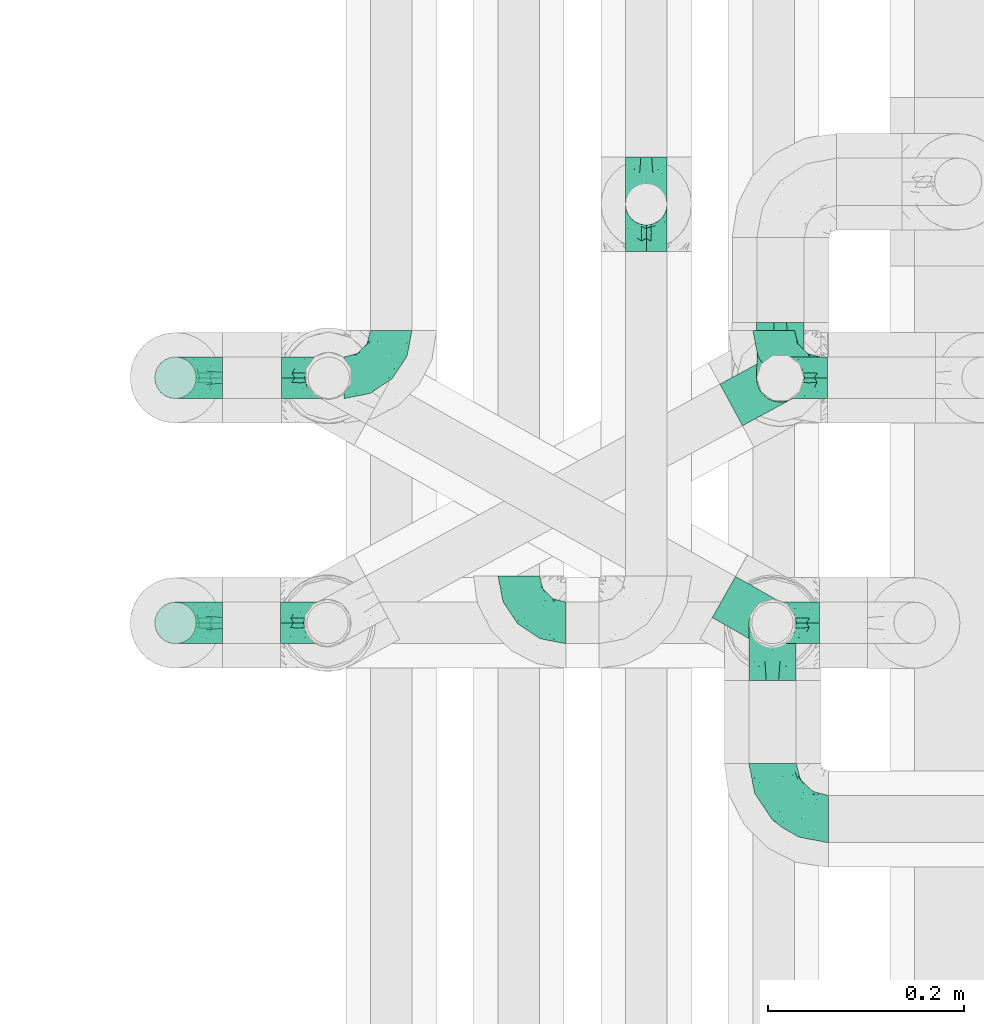
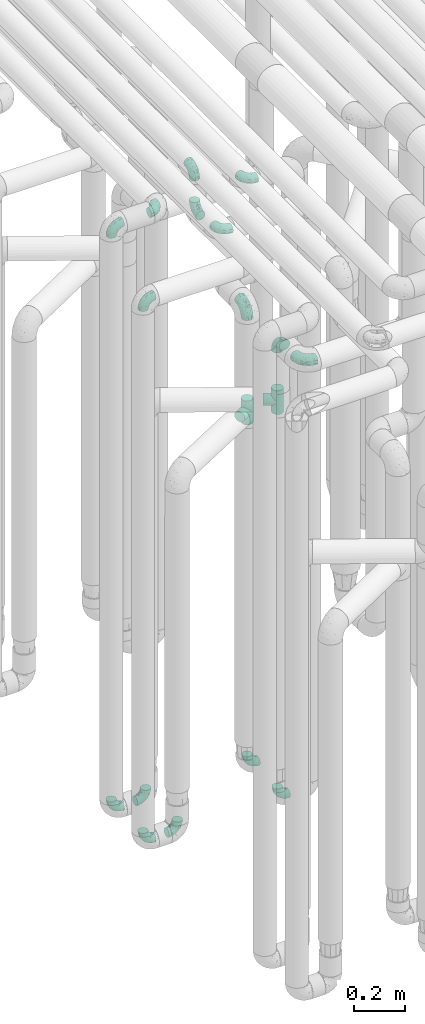
# One storey, part 600 of 827: 18 flow fittings.
"""IFC2X3 building model written with IfcOpenShell, lengths in millimetres."""

from ifc_helpers import new_model, entity, si_unit, converted_unit, derived_unit, direction, frame, origin, place, context, subcontext, project, spatial, faceted_brep, source, transform, mapped, material, type_object, type_shapes, element, save


model = new_model("IFC2X3")

# Units and contexts
model_context = context("Model", 3, precision=0.01, world=origin(), true_north=direction((6.12303176911189e-17, 1.0)))
body_context = subcontext(model_context, "Body", "Model", "MODEL_VIEW")
ifc_project = project(units=[si_unit("LENGTHUNIT", "METRE", prefix="MILLI"), si_unit("AREAUNIT", "SQUARE_METRE"), si_unit("VOLUMEUNIT", "CUBIC_METRE"), converted_unit("PLANEANGLEUNIT", "DEGREE", entity("IfcRatioMeasure", 0.0174532925199433), si_unit("PLANEANGLEUNIT", "RADIAN"), dimensions=[0, 0, 0, 0, 0, 0, 0]), si_unit("MASSUNIT", "GRAM", prefix="KILO"), derived_unit("MASSDENSITYUNIT", [(si_unit("MASSUNIT", "GRAM", prefix="KILO"), 1), (si_unit("LENGTHUNIT", "METRE"), -3)]), derived_unit("MOMENTOFINERTIAUNIT", [(si_unit("LENGTHUNIT", "METRE"), 4)]), si_unit("TIMEUNIT", "SECOND"), si_unit("FREQUENCYUNIT", "HERTZ"), si_unit("THERMODYNAMICTEMPERATUREUNIT", "DEGREE_CELSIUS"), derived_unit("THERMALTRANSMITTANCEUNIT", [(si_unit("MASSUNIT", "GRAM", prefix="KILO"), 1), (si_unit("THERMODYNAMICTEMPERATUREUNIT", "KELVIN"), -1), (si_unit("TIMEUNIT", "SECOND"), -3)]), derived_unit("VOLUMETRICFLOWRATEUNIT", [(si_unit("LENGTHUNIT", "METRE"), 3), (si_unit("TIMEUNIT", "SECOND"), -1)]), derived_unit("MASSFLOWRATEUNIT", [(si_unit("MASSUNIT", "GRAM", prefix="KILO"), 1), (si_unit("TIMEUNIT", "SECOND"), -1)]), derived_unit("ROTATIONALFREQUENCYUNIT", [(si_unit("TIMEUNIT", "SECOND"), -1)]), si_unit("ELECTRICCURRENTUNIT", "AMPERE"), si_unit("ELECTRICVOLTAGEUNIT", "VOLT"), si_unit("POWERUNIT", "WATT"), si_unit("FORCEUNIT", "NEWTON", prefix="KILO"), si_unit("ILLUMINANCEUNIT", "LUX"), si_unit("LUMINOUSFLUXUNIT", "LUMEN"), si_unit("LUMINOUSINTENSITYUNIT", "CANDELA"), derived_unit("USERDEFINED", [(si_unit("MASSUNIT", "GRAM", prefix="KILO"), -1), (si_unit("LENGTHUNIT", "METRE"), -2), (si_unit("TIMEUNIT", "SECOND"), 3), (si_unit("LUMINOUSFLUXUNIT", "LUMEN"), 1)]), derived_unit("LINEARVELOCITYUNIT", [(si_unit("LENGTHUNIT", "METRE"), 1), (si_unit("TIMEUNIT", "SECOND"), -1)]), si_unit("PRESSUREUNIT", "PASCAL"), derived_unit("USERDEFINED", [(si_unit("LENGTHUNIT", "METRE"), -2), (si_unit("MASSUNIT", "GRAM", prefix="KILO"), 1), (si_unit("TIMEUNIT", "SECOND"), -2)]), derived_unit("LINEARFORCEUNIT", [(si_unit("MASSUNIT", "GRAM", prefix="KILO"), 1), (si_unit("LENGTHUNIT", "METRE"), 1), (si_unit("TIMEUNIT", "SECOND"), -2), (si_unit("LENGTHUNIT", "METRE"), -1)]), derived_unit("PLANARFORCEUNIT", [(si_unit("MASSUNIT", "GRAM", prefix="KILO"), 1), (si_unit("LENGTHUNIT", "METRE"), 1), (si_unit("TIMEUNIT", "SECOND"), -2), (si_unit("LENGTHUNIT", "METRE"), -2)])], contexts=[model_context])

# Site, building, storey
site_placement = place(None, origin())
site = spatial("IfcSite", under=ifc_project, at=site_placement, CompositionType="ELEMENT")
building_placement = place(site_placement, origin())
building = spatial("IfcBuilding", under=site, at=building_placement, CompositionType="ELEMENT")
storey_placement = place(building_placement, frame((0.0, 0.0, 28200.0)))
storey = spatial("IfcBuildingStorey", under=building, at=storey_placement, Name="08", CompositionType="ELEMENT", Elevation=28200.0)

# Flow fittings
ifc_material = material()
pipe_fitting_type_1 = type_object("IfcPipeFittingType", Name="ADSK_1", PredefinedType="NOTDEFINED", material=ifc_material)
shared_shape_1 = source(origin(), body_context, "Body", "Brep", [
    faceted_brep([(-57.0, 12.07, -20.91), (-57.0, 6.25, -23.33), (-57.0, 0.0, -24.15), (-57.0, -6.25, -23.33), (-57.0, -12.08, -20.91), (-57.0, -17.08, -17.08), (-57.0, -20.91, -12.08), (-57.0, -23.33, -6.25), (-57.0, -24.15, 0.0), (-57.0, -23.33, 6.25), (-57.0, -20.91, 12.07), (-57.0, -17.08, 17.08), (-57.0, -12.08, 20.91), (-57.0, -6.25, 23.33), (-57.0, 0.0, 24.15), (-57.0, 6.25, 23.33), (-57.0, 12.07, 20.91), (-57.0, 17.08, 17.08), (-57.0, 20.91, 12.07), (-57.0, 23.33, 6.25), (-57.0, 24.15, 0.0), (-57.0, 23.33, -6.25), (-57.0, 20.91, -12.08), (-57.0, 17.08, -17.08), (0.0, 57.0, -24.15), (-6.25, 57.0, -23.33), (-12.07, 57.0, -20.91), (-17.08, 57.0, -17.08), (-20.91, 57.0, -12.08), (-23.33, 57.0, -6.25), (-24.15, 57.0, 0.0), (-23.33, 57.0, 6.25), (-20.91, 57.0, 12.07), (-17.08, 57.0, 17.08), (-12.07, 57.0, 20.91), (-6.25, 57.0, 23.33), (0.0, 57.0, 24.15), (6.25, 57.0, 23.33), (12.08, 57.0, 20.91), (17.08, 57.0, 17.08), (20.91, 57.0, 12.07), (23.33, 57.0, 6.25), (24.15, 57.0, 0.0), (23.33, 57.0, -6.25), (20.91, 57.0, -12.08), (17.08, 57.0, -17.08), (12.08, 57.0, -20.91), (6.25, 57.0, -23.33), (14.9, 21.14, 6.17), (13.61, 24.64, 12.48), (6.23, 8.95, 8.98), (-41.47, -21.06, 0.0), (-41.92, -18.38, 13.72), (-24.64, -13.61, 12.48), (-37.37, -13.24, 18.15), (-6.8, -4.93, 8.18), (-21.76, -15.19, 6.22), (-12.78, -9.18, 0.0), (-37.73, -20.51, 7.75), (-7.38, 7.38, 20.24), (-23.37, -4.26, 20.42), (-11.9, -3.19, 15.86), (-42.14, -8.7, 21.82), (13.24, 37.37, 18.15), (9.33, 23.53, 16.85), (4.26, 23.37, 20.42), (2.77, 10.92, 15.55), (-29.46, 0.91, 23.52), (-44.13, 20.56, 15.69), (-39.25, 26.33, 10.88), (-49.02, 22.92, 9.96), (-34.58, 23.87, 17.15), (-15.8, 6.8, 22.81), (-8.67, 20.47, 23.88), (-18.12, 12.9, 24.08), (-48.29, 14.92, 19.65), (-44.06, -2.85, 23.78), (-9.23, 48.95, 22.58), (-3.78, 42.74, 24.07), (-40.34, 4.26, 24.09), (-44.02, 26.14, 5.46), (-44.04, 9.88, 22.74), (-4.95, 16.87, 22.52), (-2.75, 1.43, 12.5), (-25.48, 40.98, 10.71), (20.51, 37.73, 7.75), (18.38, 41.92, 13.72), (8.7, 42.14, 21.82), (-25.95, -17.97, 0.0), (2.85, 44.06, 23.78), (21.06, 41.47, 0.0), (17.97, 25.95, 0.0), (-24.04, -9.27, 17.13), (-33.26, 33.26, 5.86), (-28.55, 40.57, 0.0), (-40.57, 28.55, 0.0), (-25.29, 47.19, 4.06), (-27.01, 31.1, 16.77), (-15.7, 43.95, 19.9), (-20.27, 45.22, 15.61), (-30.53, 31.98, 12.64), (-11.28, 38.33, 22.92), (-9.97, 27.88, 24.09), (-20.15, 30.26, 21.25), (-31.25, 11.75, 23.64), (-28.75, 7.23, 24.15), (-29.53, 18.06, 22.27), (-28.44, 24.21, 20.02), (-37.55, 17.7, 20.26), (-15.88, 29.25, 22.99), (-20.82, 20.82, 23.44), (-0.91, 29.46, 23.52), (-13.5, -7.67, 12.04), (1.49, 1.56, 5.16), (8.86, 10.35, 4.59), (0.38, -0.38, 0.0), (9.18, 12.78, 0.0), (-37.37, -13.24, -18.15), (8.86, 10.35, -4.59), (-45.22, 20.27, -15.61), (-43.95, 15.7, -19.9), (-38.33, 11.28, -22.92), (-48.95, 9.23, -22.58), (-47.19, 25.29, -4.06), (-33.26, 33.26, -5.86), (18.38, 41.92, -13.72), (-30.26, 20.15, -21.25), (2.85, 44.06, -23.78), (-4.26, 40.34, -24.09), (-40.98, 25.48, -10.71), (-41.92, -18.38, -13.72), (9.25, 23.5, -16.92), (4.26, 23.37, -20.42), (13.24, 37.37, -18.15), (-37.73, -20.51, -7.75), (-11.75, 31.25, -23.64), (-7.23, 28.75, -24.15), (-12.9, 18.12, -24.08), (8.7, 42.14, -21.82), (-44.06, -2.85, -23.78), (-6.8, 15.8, -22.81), (-20.47, 8.67, -23.88), (-24.64, -13.61, -12.48), (-42.74, 3.78, -24.07), (-18.06, 29.53, -22.27), (-24.21, 28.44, -20.02), (-27.88, 9.97, -24.09), (-31.1, 27.01, -16.77), (-26.14, 44.02, -5.46), (14.9, 21.14, -6.17), (20.51, 37.73, -7.75), (-9.88, 44.04, -22.74), (-20.56, 44.13, -15.69), (-21.76, -15.19, -6.22), (-13.5, -7.67, -12.04), (-24.14, -9.76, -16.74), (-11.9, -3.19, -15.86), (-14.92, 48.29, -19.65), (-23.37, -4.26, -20.42), (-0.91, 29.46, -23.52), (-26.33, 39.25, -10.88), (-23.87, 34.58, -17.15), (-42.14, -8.7, -21.82), (-22.92, 49.02, -9.96), (13.61, 24.64, -12.48), (-31.98, 30.53, -12.64), (-16.87, 4.95, -22.52), (-17.7, 37.55, -20.26), (-29.25, 15.88, -22.99), (-20.82, 20.82, -23.44), (-29.46, 0.91, -23.52), (-7.38, 7.38, -20.24), (2.77, 10.92, -15.55), (6.23, 8.95, -8.98), (-6.8, -4.93, -8.18), (-2.81, 1.41, -12.54), (1.49, 1.56, -5.16)], [[[0, 1, 2, 3, 4, 5, 6, 7, 8, 9, 10, 11, 12, 13, 14, 15, 16, 17, 18, 19, 20, 21, 22, 23]], [[24, 25, 26, 27, 28, 29, 30, 31, 32, 33, 34, 35, 36, 37, 38, 39, 40, 41, 42, 43, 44, 45, 46, 47]], [[48, 49, 50]], [[9, 8, 51]], [[52, 53, 54]], [[55, 56, 57]], [[10, 58, 52]], [[9, 58, 10]], [[59, 60, 61]], [[54, 12, 11]], [[54, 62, 12]], [[63, 39, 38]], [[64, 65, 66]], [[62, 60, 67]], [[68, 69, 70]], [[71, 69, 68]], [[72, 73, 74]], [[16, 75, 17]], [[13, 76, 14]], [[35, 77, 78]], [[14, 79, 15]], [[17, 68, 18]], [[14, 76, 79]], [[20, 19, 80]], [[70, 19, 18]], [[81, 15, 79]], [[15, 81, 16]], [[73, 72, 82]], [[66, 83, 50]], [[32, 31, 84]], [[85, 86, 49]], [[63, 87, 65]], [[56, 58, 88]], [[36, 89, 37]], [[85, 41, 40]], [[36, 35, 78]], [[90, 41, 85]], [[40, 39, 86]], [[12, 62, 13]], [[86, 85, 40]], [[48, 85, 49]], [[85, 91, 90]], [[87, 38, 37]], [[92, 60, 54]], [[80, 69, 93]], [[93, 94, 95]], [[10, 52, 11]], [[94, 96, 30]], [[97, 98, 99]], [[80, 93, 95]], [[100, 97, 84]], [[99, 98, 33]], [[101, 102, 78]], [[103, 101, 98]], [[96, 31, 30]], [[77, 98, 101]], [[77, 35, 34]], [[34, 33, 98]], [[9, 51, 58]], [[87, 63, 38]], [[104, 105, 74]], [[106, 103, 107]], [[106, 81, 104]], [[75, 68, 17]], [[108, 107, 71]], [[33, 32, 99]], [[109, 103, 110]], [[101, 109, 102]], [[89, 78, 111]], [[53, 52, 58]], [[54, 11, 52]], [[60, 62, 54]], [[88, 58, 51]], [[76, 62, 67]], [[53, 112, 92]], [[60, 59, 72]], [[39, 63, 86]], [[49, 86, 63]], [[89, 87, 37]], [[42, 41, 90]], [[111, 82, 65]], [[111, 65, 87]], [[65, 59, 66]], [[104, 81, 79]], [[75, 81, 108]], [[32, 84, 99]], [[97, 99, 84]], [[98, 97, 103]], [[106, 107, 108]], [[74, 102, 110]], [[111, 78, 102]], [[74, 110, 104]], [[74, 67, 72]], [[61, 92, 112]], [[66, 59, 61]], [[56, 53, 58]], [[66, 50, 49]], [[61, 112, 83]], [[66, 49, 64]], [[78, 89, 36]], [[87, 89, 111]], [[62, 76, 13]], [[79, 76, 67]], [[100, 93, 69]], [[96, 93, 84]], [[55, 113, 50]], [[113, 114, 50]], [[104, 79, 105]], [[106, 104, 110]], [[20, 80, 95]], [[85, 48, 91]], [[115, 114, 113]], [[116, 91, 48]], [[70, 80, 19]], [[93, 96, 94]], [[84, 31, 96]], [[103, 106, 110]], [[81, 106, 108]], [[103, 97, 107]], [[71, 107, 97]], [[71, 97, 100]], [[108, 71, 68]], [[79, 67, 105]], [[67, 74, 105]], [[115, 113, 57]], [[112, 56, 55]], [[56, 88, 57]], [[60, 72, 67]], [[82, 72, 59]], [[65, 82, 59]], [[82, 111, 73]], [[111, 102, 73]], [[102, 74, 73]], [[81, 75, 16]], [[68, 75, 108]], [[68, 70, 18]], [[80, 70, 69]], [[98, 77, 34]], [[78, 77, 101]], [[93, 100, 84]], [[71, 100, 69]], [[102, 109, 110]], [[101, 103, 109]], [[53, 92, 54]], [[61, 60, 92]], [[56, 112, 53]], [[83, 112, 55]], [[50, 83, 55]], [[61, 83, 66]], [[49, 63, 64]], [[65, 64, 63]], [[57, 113, 55]], [[114, 115, 116]], [[116, 48, 114]], [[48, 50, 114]], [[117, 5, 4]], [[116, 115, 118]], [[119, 120, 23]], [[121, 122, 120]], [[95, 123, 20]], [[0, 23, 120]], [[124, 95, 94]], [[125, 45, 44]], [[121, 120, 126]], [[24, 127, 128]], [[22, 21, 129]], [[0, 122, 1]], [[5, 117, 130]], [[131, 132, 133]], [[134, 88, 51]], [[135, 136, 137]], [[6, 5, 130]], [[46, 138, 47]], [[139, 3, 2]], [[140, 141, 137]], [[6, 134, 7]], [[134, 130, 142]], [[143, 2, 1]], [[144, 126, 145]], [[121, 146, 143]], [[147, 120, 119]], [[94, 148, 124]], [[149, 150, 91]], [[30, 29, 148]], [[151, 25, 128]], [[27, 152, 28]], [[134, 153, 88]], [[154, 155, 156]], [[27, 26, 157]], [[151, 26, 25]], [[155, 158, 156]], [[24, 47, 127]], [[1, 122, 143]], [[138, 132, 159]], [[160, 152, 161]], [[24, 128, 25]], [[46, 133, 138]], [[162, 117, 4]], [[148, 160, 124]], [[152, 160, 163]], [[154, 142, 155]], [[45, 125, 133]], [[133, 46, 45]], [[125, 164, 133]], [[51, 7, 134]], [[42, 90, 43]], [[165, 147, 129]], [[153, 134, 142]], [[43, 150, 44]], [[162, 4, 3]], [[141, 140, 166]], [[117, 162, 158]], [[163, 29, 28]], [[43, 90, 150]], [[123, 21, 20]], [[144, 151, 135]], [[157, 152, 27]], [[167, 145, 161]], [[23, 22, 119]], [[168, 126, 169]], [[121, 168, 146]], [[139, 143, 170]], [[142, 130, 117]], [[8, 7, 51]], [[134, 6, 130]], [[139, 162, 3]], [[170, 166, 158]], [[170, 158, 162]], [[158, 171, 156]], [[44, 150, 125]], [[91, 150, 90]], [[164, 125, 150]], [[132, 138, 133]], [[127, 138, 159]], [[131, 164, 172]], [[132, 171, 140]], [[135, 151, 128]], [[157, 151, 167]], [[22, 129, 119]], [[147, 119, 129]], [[120, 147, 126]], [[144, 145, 167]], [[137, 146, 169]], [[170, 143, 146]], [[137, 169, 135]], [[137, 159, 140]], [[171, 172, 156]], [[173, 174, 175]], [[156, 175, 154]], [[174, 57, 153]], [[132, 172, 171]], [[172, 164, 173]], [[143, 139, 2]], [[162, 139, 170]], [[138, 127, 47]], [[128, 127, 159]], [[165, 124, 160]], [[123, 124, 129]], [[149, 173, 164]], [[176, 174, 173]], [[135, 128, 136]], [[144, 135, 169]], [[150, 149, 164]], [[176, 118, 115]], [[149, 91, 116]], [[30, 148, 94]], [[163, 148, 29]], [[124, 123, 95]], [[129, 21, 123]], [[126, 144, 169]], [[151, 144, 167]], [[126, 147, 145]], [[161, 145, 147]], [[161, 147, 165]], [[167, 161, 152]], [[128, 159, 136]], [[159, 137, 136]], [[154, 153, 142]], [[132, 140, 159]], [[174, 176, 57]], [[57, 88, 153]], [[166, 140, 171]], [[158, 166, 171]], [[166, 170, 141]], [[170, 146, 141]], [[146, 137, 141]], [[151, 157, 26]], [[152, 157, 167]], [[152, 163, 28]], [[148, 163, 160]], [[120, 122, 0]], [[143, 122, 121]], [[124, 165, 129]], [[161, 165, 160]], [[146, 168, 169]], [[121, 126, 168]], [[142, 117, 155]], [[158, 155, 117]], [[175, 156, 172]], [[153, 154, 174]], [[173, 175, 172]], [[174, 154, 175]], [[164, 131, 133]], [[172, 132, 131]], [[176, 173, 118]], [[57, 176, 115]], [[173, 149, 118]], [[149, 116, 118]]]),
])
type_shapes(pipe_fitting_type_1, [shared_shape_1])
for number, where, z_axis, x_axis, name in (
    (1, (35736.85, 11805.67, 2600.0), (-1.0, 0.0, 0.0), (0.0, 0.0, 1.0), "ADSK_1"),
    (2, (35728.78, 11554.46, 2600.0), (1.0, 0.0, 0.0), (0.0, 0.0, 1.0), "ADSK_1"),
    (3, (35728.78, 11356.08, 2600.0), (0.0, 0.0, 1.0), (0.0, -1.0, 0.0), "ADSK_1"),
):
    element("IfcFlowFitting", number, at=place(storey_placement, frame(where, z_axis=z_axis, x_axis=x_axis)), inside=storey, type_object=pipe_fitting_type_1, material=ifc_material, Name=name, ObjectType="ADSK_1", context=body_context, shape_type="MappedRepresentation", body=[
        mapped(shared_shape_1, transform((0.0, 0.0, 0.0), scale=1.0)),
    ])
pipe_fitting_type_2 = type_object("IfcPipeFittingType", Name="ADSK_1", PredefinedType="NOTDEFINED", material=ifc_material)
shared_shape_2 = source(origin(), body_context, "Body", "Brep", [
    faceted_brep([(-48.0, 10.6, -18.36), (-48.0, 5.49, -20.48), (-48.0, 0.0, -21.2), (-48.0, -5.49, -20.48), (-48.0, -10.6, -18.36), (-48.0, -14.99, -14.99), (-48.0, -18.36, -10.6), (-48.0, -20.48, -5.49), (-48.0, -21.2, 0.0), (-48.0, -20.48, 5.49), (-48.0, -18.36, 10.6), (-48.0, -14.99, 14.99), (-48.0, -10.6, 18.36), (-48.0, -5.49, 20.48), (-48.0, 0.0, 21.2), (-48.0, 5.49, 20.48), (-48.0, 10.6, 18.36), (-48.0, 14.99, 14.99), (-48.0, 18.36, 10.6), (-48.0, 20.48, 5.49), (-48.0, 21.2, 0.0), (-48.0, 20.48, -5.49), (-48.0, 18.36, -10.6), (-48.0, 14.99, -14.99), (0.0, 48.0, -21.2), (-5.49, 48.0, -20.48), (-10.6, 48.0, -18.36), (-14.99, 48.0, -14.99), (-18.36, 48.0, -10.6), (-20.48, 48.0, -5.49), (-21.2, 48.0, 0.0), (-20.48, 48.0, 5.49), (-18.36, 48.0, 10.6), (-14.99, 48.0, 14.99), (-10.6, 48.0, 18.36), (-5.49, 48.0, 20.48), (0.0, 48.0, 21.2), (5.49, 48.0, 20.48), (10.6, 48.0, 18.36), (14.99, 48.0, 14.99), (18.36, 48.0, 10.6), (20.48, 48.0, 5.49), (21.2, 48.0, 0.0), (20.48, 48.0, -5.49), (18.36, 48.0, -10.6), (14.99, 48.0, -14.99), (10.6, 48.0, -18.36), (5.49, 48.0, -20.48), (-35.25, -16.22, 12.01), (-34.76, -18.57, 0.0), (-20.87, -12.37, 10.9), (-31.49, -11.78, 15.9), (-37.0, -2.58, 20.86), (-33.89, 3.62, 21.15), (-31.81, -18.14, 6.76), (-5.78, 5.78, 17.67), (-19.42, -4.1, 17.86), (-9.6, -3.39, 13.73), (-35.44, -7.73, 19.13), (11.78, 31.49, 15.9), (-5.93, -5.46, 6.95), (-18.45, -13.78, 5.46), (-10.29, -8.43, 0.0), (-24.6, 0.55, 20.62), (-37.28, 17.94, 13.81), (-33.38, 22.85, 9.59), (-41.46, 20.06, 8.75), (-29.51, 20.45, 15.16), (-15.04, 10.79, 21.13), (-7.08, 16.98, 20.93), (-8.39, 23.51, 21.15), (-40.86, 13.03, 17.26), (-8.05, 41.26, 19.83), (-3.21, 35.97, 21.14), (8.53, 19.66, 14.74), (4.1, 19.42, 17.86), (-37.72, 22.66, 4.78), (-37.07, 8.58, 19.98), (-13.0, 5.43, 19.97), (-3.78, 13.93, 19.7), (3.02, 8.69, 13.43), (-2.27, -0.05, 10.65), (6.22, 6.99, 7.09), (-22.25, 34.6, 9.45), (18.14, 31.81, 6.76), (16.22, 35.25, 12.01), (12.37, 20.87, 10.9), (7.73, 35.44, 19.13), (-21.52, -15.93, 0.0), (2.58, 37.0, 20.86), (18.57, 34.76, 0.0), (13.78, 18.45, 5.46), (15.93, 21.52, 0.0), (-20.03, -8.54, 14.9), (-28.6, 28.6, 5.16), (-24.79, 34.6, 0.0), (-34.6, 24.79, 0.0), (-22.81, 37.41, 4.68), (-23.36, 26.33, 14.79), (-13.68, 37.05, 17.49), (-17.72, 38.12, 13.73), (-26.25, 27.3, 11.24), (-9.71, 32.34, 20.14), (-17.26, 25.6, 18.71), (-26.33, 9.99, 20.77), (-24.06, 6.05, 21.2), (-25.02, 15.46, 19.56), (-24.3, 20.72, 17.57), (-31.95, 15.23, 17.8), (-13.53, 24.7, 20.21), (-17.6, 17.6, 20.6), (-0.55, 24.6, 20.62), (-11.41, -7.48, 10.43), (0.93, -0.93, 0.0), (8.43, 10.29, 0.0), (-11.41, -7.48, -10.43), (-20.1, -8.84, -14.66), (-9.6, -3.39, -13.73), (7.73, 35.44, -19.13), (4.1, 19.42, -17.86), (-0.55, 24.6, -20.62), (-38.12, 17.72, -13.73), (-37.05, 13.68, -17.49), (-32.34, 9.71, -20.14), (-41.26, 8.05, -19.83), (-37.41, 22.81, -4.68), (-23.51, 8.39, -21.15), (-35.97, 3.21, -21.14), (-28.6, 28.6, -5.16), (-31.81, -18.14, -6.76), (-18.45, -13.78, -5.46), (-25.6, 17.26, -18.71), (-19.42, -4.1, -17.86), (-17.94, 37.28, -13.81), (-22.85, 33.38, -9.59), (-20.06, 41.46, -8.75), (-31.49, -11.78, -15.9), (-35.25, -16.22, -12.01), (8.53, 19.66, -14.74), (11.78, 31.49, -15.9), (-9.99, 26.33, -20.77), (-6.05, 24.06, -21.2), (-10.79, 15.04, -21.13), (-37.0, -2.58, -20.86), (-16.98, 7.08, -20.93), (-5.43, 13.0, -19.97), (-13.93, 3.78, -19.7), (-20.87, -12.37, -10.9), (-26.33, 23.36, -14.79), (-22.66, 37.72, -4.78), (13.78, 18.45, -5.46), (18.14, 31.81, -6.76), (-15.46, 25.02, -19.56), (-20.72, 24.3, -17.57), (16.22, 35.25, -12.01), (-13.03, 40.86, -17.26), (-8.58, 37.07, -19.98), (2.58, 37.0, -20.86), (-3.62, 33.89, -21.15), (-34.6, 22.25, -9.45), (6.22, 6.99, -7.09), (-20.45, 29.51, -15.16), (-35.44, -7.73, -19.13), (12.37, 20.87, -10.9), (-27.3, 26.25, -11.24), (-15.23, 31.95, -17.8), (-24.7, 13.53, -20.21), (-24.6, 0.55, -20.62), (-5.78, 5.78, -17.67), (-17.6, 17.6, -20.6), (3.02, 8.69, -13.43), (-5.93, -5.46, -6.95), (-2.27, -0.05, -10.65)], [[[0, 1, 2, 3, 4, 5, 6, 7, 8, 9, 10, 11, 12, 13, 14, 15, 16, 17, 18, 19, 20, 21, 22, 23]], [[24, 25, 26, 27, 28, 29, 30, 31, 32, 33, 34, 35, 36, 37, 38, 39, 40, 41, 42, 43, 44, 45, 46, 47]], [[10, 48, 11]], [[9, 8, 49]], [[48, 50, 51]], [[14, 52, 53]], [[10, 54, 48]], [[9, 54, 10]], [[55, 56, 57]], [[51, 12, 11]], [[51, 58, 12]], [[59, 39, 38]], [[60, 61, 62]], [[58, 56, 63]], [[64, 65, 66]], [[67, 65, 64]], [[68, 69, 70]], [[16, 71, 17]], [[13, 52, 14]], [[35, 72, 73]], [[14, 53, 15]], [[17, 64, 18]], [[74, 59, 75]], [[20, 19, 76]], [[66, 19, 18]], [[77, 15, 53]], [[15, 77, 16]], [[69, 78, 79]], [[80, 81, 82]], [[32, 31, 83]], [[84, 85, 86]], [[59, 87, 75]], [[61, 54, 88]], [[36, 89, 37]], [[84, 41, 40]], [[36, 35, 73]], [[90, 41, 84]], [[40, 39, 85]], [[12, 58, 13]], [[85, 84, 40]], [[91, 84, 86]], [[84, 92, 90]], [[87, 38, 37]], [[93, 56, 51]], [[65, 94, 76]], [[94, 95, 96]], [[84, 91, 92]], [[95, 97, 30]], [[98, 99, 100]], [[76, 94, 96]], [[101, 98, 83]], [[100, 99, 33]], [[102, 70, 73]], [[103, 102, 99]], [[94, 97, 95]], [[72, 99, 102]], [[72, 35, 34]], [[34, 33, 99]], [[9, 49, 54]], [[87, 59, 38]], [[104, 105, 68]], [[106, 103, 107]], [[106, 77, 104]], [[71, 64, 17]], [[108, 107, 67]], [[33, 32, 100]], [[109, 103, 110]], [[102, 109, 70]], [[89, 73, 111]], [[50, 48, 54]], [[51, 11, 48]], [[56, 58, 51]], [[88, 54, 49]], [[52, 58, 63]], [[50, 112, 93]], [[56, 55, 78]], [[39, 59, 85]], [[86, 85, 59]], [[89, 87, 37]], [[42, 41, 90]], [[111, 79, 75]], [[111, 75, 87]], [[75, 55, 80]], [[104, 77, 53]], [[71, 77, 108]], [[32, 83, 100]], [[98, 100, 83]], [[99, 98, 103]], [[106, 107, 108]], [[68, 70, 110]], [[111, 73, 70]], [[68, 110, 104]], [[68, 63, 78]], [[57, 93, 112]], [[80, 55, 57]], [[61, 50, 54]], [[80, 82, 86]], [[81, 57, 112]], [[74, 86, 59]], [[60, 113, 82]], [[82, 114, 91]], [[101, 94, 65]], [[97, 94, 83]], [[73, 89, 36]], [[87, 89, 111]], [[58, 52, 13]], [[53, 52, 63]], [[104, 53, 105]], [[106, 104, 110]], [[20, 76, 96]], [[76, 19, 66]], [[103, 106, 110]], [[77, 106, 108]], [[103, 98, 107]], [[67, 107, 98]], [[67, 98, 101]], [[108, 67, 64]], [[53, 63, 105]], [[63, 68, 105]], [[83, 31, 97]], [[30, 97, 31]], [[62, 113, 60]], [[112, 61, 60]], [[61, 88, 62]], [[86, 82, 91]], [[56, 78, 63]], [[114, 82, 113]], [[114, 92, 91]], [[79, 78, 55]], [[75, 79, 55]], [[69, 79, 111]], [[70, 69, 111]], [[78, 69, 68]], [[77, 71, 16]], [[64, 71, 108]], [[64, 66, 18]], [[76, 66, 65]], [[99, 72, 34]], [[73, 72, 102]], [[94, 101, 83]], [[67, 101, 65]], [[75, 80, 74]], [[80, 86, 74]], [[70, 109, 110]], [[102, 103, 109]], [[50, 93, 51]], [[57, 56, 93]], [[61, 112, 50]], [[81, 112, 60]], [[82, 81, 60]], [[80, 57, 81]], [[115, 116, 117]], [[118, 119, 120]], [[121, 122, 23]], [[123, 124, 122]], [[96, 125, 20]], [[123, 126, 127]], [[128, 96, 95]], [[129, 130, 88]], [[123, 122, 131]], [[116, 132, 117]], [[133, 134, 135]], [[0, 124, 1]], [[5, 136, 137]], [[138, 119, 139]], [[129, 88, 49]], [[140, 141, 142]], [[6, 5, 137]], [[46, 118, 47]], [[143, 3, 2]], [[144, 145, 146]], [[6, 129, 7]], [[129, 137, 147]], [[127, 2, 1]], [[148, 122, 121]], [[128, 125, 96]], [[134, 128, 149]], [[95, 149, 128]], [[150, 151, 92]], [[30, 29, 149]], [[152, 131, 153]], [[27, 133, 28]], [[154, 45, 44]], [[136, 5, 4]], [[27, 26, 155]], [[156, 26, 25]], [[24, 157, 158]], [[24, 47, 157]], [[22, 21, 159]], [[160, 150, 114]], [[134, 133, 161]], [[142, 144, 126]], [[46, 139, 118]], [[162, 136, 4]], [[156, 25, 158]], [[1, 124, 127]], [[115, 147, 116]], [[45, 154, 139]], [[139, 46, 45]], [[154, 163, 139]], [[162, 4, 3]], [[42, 90, 43]], [[130, 129, 147]], [[49, 7, 129]], [[43, 151, 44]], [[0, 23, 122]], [[24, 158, 25]], [[136, 162, 132]], [[135, 29, 28]], [[43, 90, 151]], [[164, 148, 159]], [[152, 156, 140]], [[155, 133, 27]], [[165, 153, 161]], [[23, 22, 121]], [[123, 131, 166]], [[123, 166, 126]], [[143, 127, 167]], [[147, 137, 136]], [[8, 7, 49]], [[129, 6, 137]], [[143, 162, 3]], [[167, 146, 132]], [[167, 132, 162]], [[132, 168, 117]], [[44, 151, 154]], [[92, 151, 90]], [[163, 154, 151]], [[119, 118, 139]], [[157, 118, 120]], [[138, 139, 163]], [[119, 168, 145]], [[140, 156, 158]], [[155, 156, 165]], [[22, 159, 121]], [[148, 121, 159]], [[122, 148, 131]], [[152, 153, 165]], [[142, 126, 169]], [[167, 127, 126]], [[142, 169, 140]], [[142, 120, 145]], [[168, 170, 117]], [[160, 171, 172]], [[115, 172, 171]], [[171, 62, 130]], [[119, 170, 168]], [[170, 163, 160]], [[150, 163, 151]], [[113, 171, 160]], [[164, 128, 134]], [[125, 128, 159]], [[127, 143, 2]], [[162, 143, 167]], [[118, 157, 47]], [[158, 157, 120]], [[140, 158, 141]], [[152, 140, 169]], [[30, 149, 95]], [[149, 29, 135]], [[131, 152, 169]], [[156, 152, 165]], [[131, 148, 153]], [[161, 153, 148]], [[161, 148, 164]], [[165, 161, 133]], [[158, 120, 141]], [[120, 142, 141]], [[159, 21, 125]], [[20, 125, 21]], [[115, 130, 147]], [[114, 113, 160]], [[62, 171, 113]], [[62, 88, 130]], [[160, 163, 150]], [[150, 92, 114]], [[119, 145, 120]], [[146, 145, 168]], [[132, 146, 168]], [[144, 146, 167]], [[126, 144, 167]], [[145, 144, 142]], [[156, 155, 26]], [[133, 155, 165]], [[133, 135, 28]], [[149, 135, 134]], [[122, 124, 0]], [[127, 124, 123]], [[128, 164, 159]], [[161, 164, 134]], [[163, 170, 138]], [[170, 119, 138]], [[131, 169, 166]], [[126, 166, 169]], [[147, 136, 116]], [[132, 116, 136]], [[172, 115, 117]], [[130, 115, 171]], [[117, 170, 172]], [[160, 172, 170]]]),
])
type_shapes(pipe_fitting_type_2, [shared_shape_2])
for number, where, z_axis, x_axis, name in (
    (4, (35276.24, 11806.2, 400.0), (0.0, -1.0, 0.0), (1.0, 0.0, 0.0), "ADSK_1"),
    (5, (35275.03, 11556.2, 400.0), (0.0, -1.0, 0.0), (1.0, 0.0, 0.0), "ADSK_1"),
    (6, (35728.78, 11556.17, 400.0), (0.0, 1.0, 0.0), (-1.0, 0.0, 0.0), "ADSK_1"),
    (7, (35120.03, 11806.2, 400.0), (0.0, 1.0, 0.0), (-1.0, 0.0, 0.0), "ADSK_1"),
    (8, (35120.03, 11806.2, 3200.0), (0.0, 1.0, 0.0), (0.0, 0.0, 1.0), "ADSK_1"),
):
    element("IfcFlowFitting", number, at=place(storey_placement, frame(where, z_axis=z_axis, x_axis=x_axis)), inside=storey, type_object=pipe_fitting_type_2, material=ifc_material, Name=name, ObjectType="ADSK_1", context=body_context, shape_type="MappedRepresentation", body=[
        mapped(shared_shape_2, transform((0.0, 0.0, 0.0), scale=1.0)),
    ])
flow_fitting_placement = place(storey_placement, frame((35340.03, 11806.2, 3200.0)))
element("IfcFlowFitting", 9, at=flow_fitting_placement, inside=storey, type_object=pipe_fitting_type_2, material=ifc_material, Name="ADSK_1", ObjectType="ADSK_1", context=body_context, shape_type="MappedRepresentation", body=[
    mapped(shared_shape_2, transform((0.0, 0.0, 0.0), scale=1.0)),
])
for number, where, z_axis, x_axis, name in (
    (10, (35470.03, 11556.17, 3200.0), (0.0, 0.0, 1.0), (0.0, -1.0, 0.0), "ADSK_1"),
    (11, (35730.03, 11806.2, 3200.0), (0.0, 0.0, 1.0), (0.0, -1.0, 0.0), "ADSK_1"),
    (12, (35120.03, 11556.2, 400.0), (0.0, 1.0, 0.0), (-1.0, 0.0, 0.0), "ADSK_1"),
    (13, (35600.09, 11983.2, 3200.0), (1.0, 0.0, 0.0), (0.0, -1.0, 0.0), "ADSK_1"),
    (14, (35120.03, 11556.2, 3000.0), (5.23443422123889e-05, 1.0, 0.0), (0.0, 0.0, 1.0), "ADSK_1"),
    (15, (35600.09, 11983.2, 3000.0), (-1.0, 0.0, 0.0), (0.0, 0.0, -1.0), "ADSK_1"),
    (16, (35736.85, 11806.2, 400.0), (0.0, 0.999999930761682, 0.000372124482818008), (-1.0, 0.0, 0.0), "ADSK_1"),
):
    element("IfcFlowFitting", number, at=place(storey_placement, frame(where, z_axis=z_axis, x_axis=x_axis)), inside=storey, type_object=pipe_fitting_type_2, material=ifc_material, Name=name, ObjectType="ADSK_1", context=body_context, shape_type="MappedRepresentation", body=[
        mapped(shared_shape_2, transform((0.0, 0.0, 0.0), scale=1.0)),
    ])
pipe_fitting_type_3 = type_object("IfcPipeFittingType", Name="ADSK_1", PredefinedType="NOTDEFINED", material=ifc_material)
shared_shape_3 = source(origin(), body_context, "Body", "Brep", [
    faceted_brep([(-57.0, 12.07, -20.91), (-57.0, 6.25, -23.33), (-57.0, 0.0, -24.15), (-57.0, -6.25, -23.33), (-57.0, -12.08, -20.91), (-57.0, -17.08, -17.08), (-57.0, -20.91, -12.08), (-57.0, -23.33, -6.25), (-57.0, -24.15, 0.0), (-57.0, -23.33, 6.25), (-57.0, -20.91, 12.07), (-57.0, -17.08, 17.08), (-57.0, -12.08, 20.91), (-57.0, -6.25, 23.33), (-57.0, 0.0, 24.15), (-57.0, 6.25, 23.33), (-57.0, 12.07, 20.91), (-57.0, 17.08, 17.08), (-57.0, 20.91, 12.07), (-57.0, 23.33, 6.25), (-57.0, 24.15, 0.0), (-57.0, 23.33, -6.25), (-57.0, 20.91, -12.08), (-57.0, 17.08, -17.08), (57.0, 0.0, -24.15), (57.0, 6.25, -23.33), (57.0, 12.07, -20.91), (57.0, 17.08, -17.08), (57.0, 20.91, -12.08), (57.0, 23.33, -6.25), (57.0, 24.15, 0.0), (57.0, 23.33, 6.25), (57.0, 20.91, 12.07), (57.0, 17.08, 17.08), (57.0, 12.07, 20.91), (57.0, 6.25, 23.33), (57.0, 0.0, 24.15), (57.0, -6.25, 23.33), (57.0, -12.08, 20.91), (57.0, -17.08, 17.08), (57.0, -20.91, 12.07), (57.0, -23.33, 6.25), (57.0, -24.15, 0.0), (57.0, -23.33, -6.25), (57.0, -20.91, -12.08), (57.0, -17.08, -17.08), (57.0, -12.08, -20.91), (57.0, -6.25, -23.33), (23.27, -23.27, 6.45), (24.15, -24.15, 0.0), (-24.15, -24.15, 0.0), (20.9, -20.9, 12.1), (13.54, -13.54, 20.0), (17.52, -17.52, 16.62), (-23.27, -23.27, 6.45), (-20.9, -20.9, 12.1), (-17.52, -17.52, 16.62), (-13.54, -13.54, 20.0), (-9.19, -9.19, 22.33), (9.19, -9.19, 22.33), (4.64, -4.64, 23.7), (0.0, 0.0, 24.15), (-4.64, -4.64, 23.7), (4.64, -4.64, -23.7), (0.0, 0.0, -24.15), (-4.64, -4.64, -23.7), (-9.19, -9.19, -22.33), (9.19, -9.19, -22.33), (13.54, -13.54, -20.0), (17.52, -17.52, -16.62), (20.9, -20.9, -12.1), (23.27, -23.27, -6.45), (-13.54, -13.54, -20.0), (-17.52, -17.52, -16.62), (-23.27, -23.27, -6.45), (-20.9, -20.9, -12.1), (0.0, -57.0, -24.15), (6.25, -57.0, -23.33), (12.08, -57.0, -20.91), (17.08, -57.0, -17.08), (20.91, -57.0, -12.08), (23.33, -57.0, -6.25), (24.15, -57.0, 0.0), (23.33, -57.0, 6.25), (20.91, -57.0, 12.07), (17.08, -57.0, 17.08), (12.08, -57.0, 20.91), (6.25, -57.0, 23.33), (0.0, -57.0, 24.15), (-6.25, -57.0, 23.33), (-12.07, -57.0, 20.91), (-17.08, -57.0, 17.08), (-20.91, -57.0, 12.07), (-23.33, -57.0, 6.25), (-24.15, -57.0, 0.0), (-23.33, -57.0, -6.25), (-20.91, -57.0, -12.08), (-17.08, -57.0, -17.08), (-12.07, -57.0, -20.91), (-6.25, -57.0, -23.33)], [[[0, 1, 2, 3, 4, 5, 6, 7, 8, 9, 10, 11, 12, 13, 14, 15, 16, 17, 18, 19, 20, 21, 22, 23]], [[24, 25, 26, 27, 28, 29, 30, 31, 32, 33, 34, 35, 36, 37, 38, 39, 40, 41, 42, 43, 44, 45, 46, 47]], [[41, 40, 48]], [[42, 41, 49]], [[50, 9, 8]], [[49, 41, 48]], [[40, 51, 48]], [[39, 38, 52]], [[51, 40, 53]], [[52, 53, 39]], [[53, 40, 39]], [[50, 54, 9]], [[9, 54, 10]], [[54, 55, 10]], [[56, 57, 11]], [[11, 10, 56]], [[11, 57, 12]], [[56, 10, 55]], [[12, 57, 58]], [[52, 38, 59]], [[60, 36, 61]], [[62, 61, 14]], [[59, 37, 60]], [[37, 59, 38]], [[60, 37, 36]], [[61, 36, 35, 15, 14]], [[32, 31, 19, 18]], [[17, 16, 34, 33]], [[18, 17, 33, 32]], [[35, 34, 16, 15]], [[20, 19, 31, 30]], [[62, 13, 58]], [[13, 62, 14]], [[58, 13, 12]], [[27, 23, 22, 28]], [[22, 21, 29, 28]], [[0, 23, 27, 26]], [[20, 30, 29, 21]], [[24, 47, 63]], [[24, 64, 2, 1, 25]], [[64, 24, 63]], [[2, 64, 65]], [[26, 25, 1, 0]], [[65, 66, 3]], [[2, 65, 3]], [[66, 4, 3]], [[63, 47, 67]], [[46, 45, 68]], [[69, 68, 45]], [[44, 70, 69]], [[69, 45, 44]], [[46, 68, 67]], [[43, 42, 49]], [[7, 50, 8]], [[43, 71, 44]], [[71, 43, 49]], [[44, 71, 70]], [[72, 4, 66]], [[72, 5, 4]], [[5, 72, 73]], [[5, 73, 6]], [[74, 50, 7]], [[75, 74, 6]], [[74, 7, 6]], [[75, 6, 73]], [[46, 67, 47]], [[76, 77, 78, 79, 80, 81, 82, 83, 84, 85, 86, 87, 88, 89, 90, 91, 92, 93, 94, 95, 96, 97, 98, 99]], [[50, 94, 93]], [[54, 50, 93]], [[91, 90, 57]], [[56, 92, 91]], [[54, 93, 92]], [[58, 90, 89]], [[55, 54, 92]], [[56, 55, 92]], [[58, 57, 90]], [[88, 61, 62]], [[58, 89, 62]], [[56, 91, 57]], [[62, 89, 88]], [[60, 88, 87]], [[86, 59, 87]], [[84, 83, 48]], [[53, 85, 84]], [[52, 86, 85]], [[49, 83, 82]], [[59, 60, 87]], [[52, 59, 86]], [[49, 48, 83]], [[51, 53, 84]], [[48, 51, 84]], [[52, 85, 53]], [[88, 60, 61]], [[82, 81, 49]], [[71, 49, 81]], [[69, 80, 79]], [[79, 78, 68]], [[71, 81, 80]], [[67, 78, 77]], [[70, 71, 80]], [[69, 70, 80]], [[67, 68, 78]], [[76, 64, 63]], [[67, 77, 63]], [[69, 79, 68]], [[63, 77, 76]], [[65, 76, 99]], [[98, 66, 99]], [[96, 95, 74]], [[73, 97, 96]], [[72, 98, 97]], [[50, 95, 94]], [[66, 65, 99]], [[72, 66, 98]], [[50, 74, 95]], [[75, 73, 96]], [[74, 75, 96]], [[72, 97, 73]], [[76, 65, 64]]]),
])
type_shapes(pipe_fitting_type_3, [shared_shape_3])
for number, where, z_axis, x_axis, name in (
    (17, (35728.78, 11554.46, 2305.0), (0.494757339901246, 0.869031170104872, 0.0), (0.0, 0.0, 1.0), "ADSK_1"),
    (18, (35736.85, 11805.67, 2100.0), (-0.476176251027639, 0.879349860952547, 0.0), (0.0, 0.0, 1.0), "ADSK_1"),
):
    element("IfcFlowFitting", number, at=place(storey_placement, frame(where, z_axis=z_axis, x_axis=x_axis)), inside=storey, type_object=pipe_fitting_type_3, material=ifc_material, Name=name, ObjectType="ADSK_1", context=body_context, shape_type="MappedRepresentation", body=[
        mapped(shared_shape_3, transform((0.0, 0.0, 0.0), scale=1.0)),
    ])

save(model, "model.ifc")
